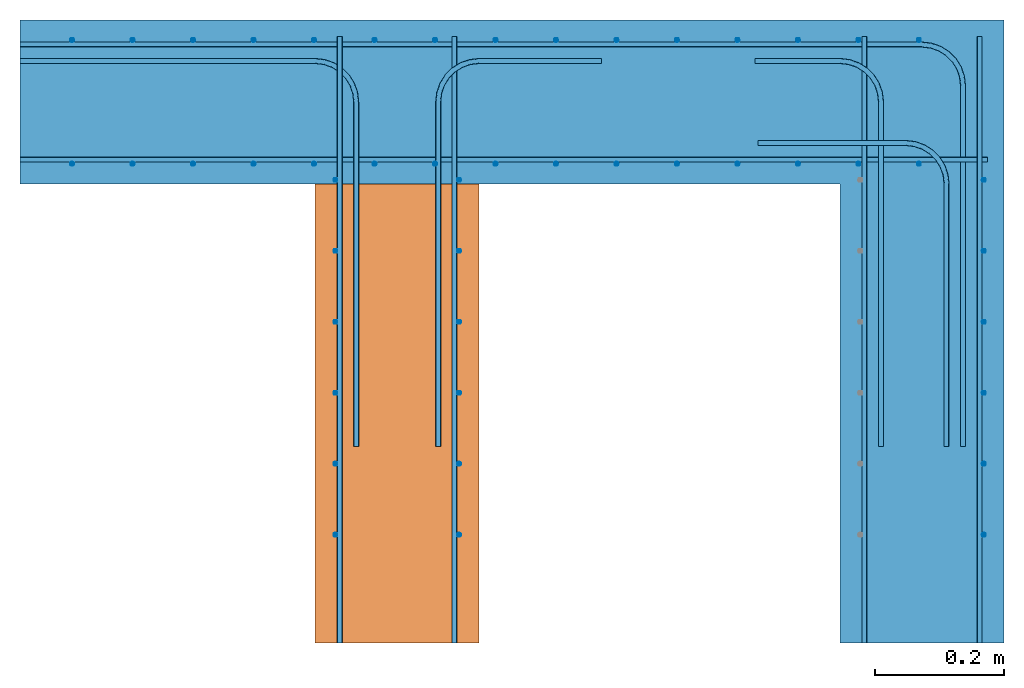
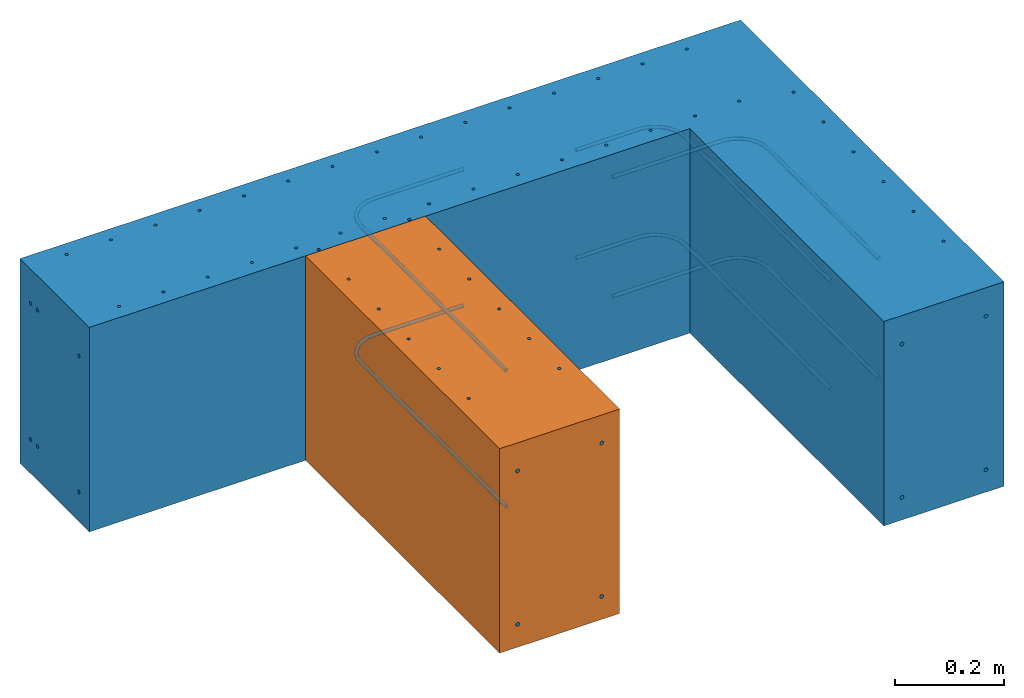
# One storey, part 1 of 2: 15 reinforcing bars, 1 proxy, 1 wall, 1 element without a shape of its own.
"""IFC4 building model written with IfcOpenShell, lengths in metres."""

from ifc_helpers import new_model, entity, si_unit, converted_unit, direction, frame, frame_2d, origin_with_axes, place, context, subcontext, project, spatial, polyline, rectangle, outline, extrude, element, aggregate, save


model = new_model("IFC4")

# Units and contexts
model_context = context("Model", 3, precision=1e-05, world=origin_with_axes(), true_north=direction((0.0, 1.0)))
body_context = subcontext(model_context, "Body", "Model", "MODEL_VIEW")
ifc_project = project(units=[si_unit("LENGTHUNIT", "METRE"), si_unit("AREAUNIT", "SQUARE_METRE"), si_unit("VOLUMEUNIT", "CUBIC_METRE"), converted_unit("PLANEANGLEUNIT", "DEGREE", entity("IfcPlaneAngleMeasure", 0.017453292519943295), si_unit("PLANEANGLEUNIT", "RADIAN"), dimensions=[0, 0, 0, 0, 0, 0, 0])], contexts=[model_context])

# Site, building, storey
site = spatial("IfcSite", under=ifc_project, CompositionType="ELEMENT")
building = spatial("IfcBuilding", under=site, Name="Default Building", CompositionType="ELEMENT")
storey = spatial("IfcBuildingStorey", under=building, Name="Detail 1", CompositionType="COMPLEX")

# Wall, proxy
placement = place(None, origin_with_axes())
wall = element("IfcWall", 1, at=placement, inside=storey, Name="Wall", PredefinedType="MOVABLE", context=body_context, shape_type="SweptSolid", body=[
    extrude(outline(polyline([(-0.964045454545477, 0.280554545454547), (0.559954545454545, 0.280554545454545), (0.559954545454545, -0.684645454545454), (0.305954545454514, -0.684645454545462), (0.305954545454492, 0.0265545454545304), (-0.964045454545499, 0.0265545454545399), (-0.964045454545477, 0.280554545454547)])), frame((0.964045454545455, -0.280554545454545, 0.0254), z_axis=(0.0, 0.0, 1.0), x_axis=(1.0, 0.0, 0.0)), (0.0, 0.0, -1.0), 0.4572),
])
proxy = element("IfcBuildingElementProxy", 2, at=placement, Name="Wall", PredefinedType="ELEMENT", context=body_context, shape_type="SweptSolid", body=[
    extrude(rectangle(XDim=0.7112, YDim=0.254, at=frame_2d((0.0, 0.0), x_axis=(0.0, 1.0))), frame((0.5842, -0.6096, 0.0254), z_axis=(0.0, 0.0, 1.0), x_axis=(1.0, 0.0, 0.0)), (0.0, 0.0, -1.0), 0.4572),
])
aggregate(wall, [proxy])

# Reinforcing bar
element("IfcReinforcingBar", 3, at=placement, inside=storey, Name="Stirrup", context=body_context, shape_type="SweptSolid", body=[
    entity("IfcSweptDiskSolid", entity("IfcCompositeCurve", [entity("IfcCompositeCurveSegment", "CONTINUOUS", True, entity("IfcPolyline", [entity("IfcCartesianPoint", [0.0808354293823238, -0.0310999994069913, -0.431799999999999]), entity("IfcCartesianPoint", [0.0808354293823238, -0.0310999994069913, 0.0254000000000015])]))], False), 0.003),
    entity("IfcSweptDiskSolid", entity("IfcCompositeCurve", [entity("IfcCompositeCurveSegment", "CONTINUOUS", True, entity("IfcPolyline", [entity("IfcCartesianPoint", [0.174521143668038, -0.0310999994069913, -0.431799999999999]), entity("IfcCartesianPoint", [0.174521143668038, -0.0310999994069913, 0.0254000000000015])]))], False), 0.003),
    entity("IfcSweptDiskSolid", entity("IfcCompositeCurve", [entity("IfcCompositeCurveSegment", "CONTINUOUS", True, entity("IfcPolyline", [entity("IfcCartesianPoint", [0.268206857953752, -0.0310999994069913, -0.431799999999999]), entity("IfcCartesianPoint", [0.268206857953752, -0.0310999994069913, 0.0254000000000015])]))], False), 0.003),
    entity("IfcSweptDiskSolid", entity("IfcCompositeCurve", [entity("IfcCompositeCurveSegment", "CONTINUOUS", True, entity("IfcPolyline", [entity("IfcCartesianPoint", [0.361892572239467, -0.0310999994069913, -0.431799999999999]), entity("IfcCartesianPoint", [0.361892572239467, -0.0310999994069913, 0.0254000000000015])]))], False), 0.003),
    entity("IfcSweptDiskSolid", entity("IfcCompositeCurve", [entity("IfcCompositeCurveSegment", "CONTINUOUS", True, entity("IfcPolyline", [entity("IfcCartesianPoint", [0.455578286525181, -0.0310999994069913, -0.431799999999999]), entity("IfcCartesianPoint", [0.455578286525181, -0.0310999994069913, 0.0254000000000015])]))], False), 0.003),
    entity("IfcSweptDiskSolid", entity("IfcCompositeCurve", [entity("IfcCompositeCurveSegment", "CONTINUOUS", True, entity("IfcPolyline", [entity("IfcCartesianPoint", [0.549264000810895, -0.0310999994069913, -0.431799999999999]), entity("IfcCartesianPoint", [0.549264000810895, -0.0310999994069913, 0.0254000000000015])]))], False), 0.003),
    entity("IfcSweptDiskSolid", entity("IfcCompositeCurve", [entity("IfcCompositeCurveSegment", "CONTINUOUS", True, entity("IfcPolyline", [entity("IfcCartesianPoint", [0.642949715096609, -0.0310999994069913, -0.431799999999999]), entity("IfcCartesianPoint", [0.642949715096609, -0.0310999994069913, 0.0254000000000015])]))], False), 0.003),
    entity("IfcSweptDiskSolid", entity("IfcCompositeCurve", [entity("IfcCompositeCurveSegment", "CONTINUOUS", True, entity("IfcPolyline", [entity("IfcCartesianPoint", [0.736635429382324, -0.0310999994069913, -0.431799999999999]), entity("IfcCartesianPoint", [0.736635429382324, -0.0310999994069913, 0.0254000000000015])]))], False), 0.003),
    entity("IfcSweptDiskSolid", entity("IfcCompositeCurve", [entity("IfcCompositeCurveSegment", "CONTINUOUS", True, entity("IfcPolyline", [entity("IfcCartesianPoint", [0.830321143668038, -0.0310999994069913, -0.431799999999999]), entity("IfcCartesianPoint", [0.830321143668038, -0.0310999994069913, 0.0254000000000015])]))], False), 0.003),
    entity("IfcSweptDiskSolid", entity("IfcCompositeCurve", [entity("IfcCompositeCurveSegment", "CONTINUOUS", True, entity("IfcPolyline", [entity("IfcCartesianPoint", [0.924006857953752, -0.0310999994069913, -0.431799999999999]), entity("IfcCartesianPoint", [0.924006857953752, -0.0310999994069913, 0.0254000000000015])]))], False), 0.003),
    entity("IfcSweptDiskSolid", entity("IfcCompositeCurve", [entity("IfcCompositeCurveSegment", "CONTINUOUS", True, entity("IfcPolyline", [entity("IfcCartesianPoint", [1.01769257223947, -0.0310999994069913, -0.431799999999999]), entity("IfcCartesianPoint", [1.01769257223947, -0.0310999994069913, 0.0254000000000015])]))], False), 0.003),
    entity("IfcSweptDiskSolid", entity("IfcCompositeCurve", [entity("IfcCompositeCurveSegment", "CONTINUOUS", True, entity("IfcPolyline", [entity("IfcCartesianPoint", [1.11137828652518, -0.0310999994069913, -0.431799999999999]), entity("IfcCartesianPoint", [1.11137828652518, -0.0310999994069913, 0.0254000000000015])]))], False), 0.003),
    entity("IfcSweptDiskSolid", entity("IfcCompositeCurve", [entity("IfcCompositeCurveSegment", "CONTINUOUS", True, entity("IfcPolyline", [entity("IfcCartesianPoint", [1.2050640008109, -0.0310999994069913, -0.431799999999999]), entity("IfcCartesianPoint", [1.2050640008109, -0.0310999994069913, 0.0254000000000015])]))], False), 0.003),
    entity("IfcSweptDiskSolid", entity("IfcCompositeCurve", [entity("IfcCompositeCurveSegment", "CONTINUOUS", True, entity("IfcPolyline", [entity("IfcCartesianPoint", [1.29874971509661, -0.0310999994069913, -0.431799999999999]), entity("IfcCartesianPoint", [1.29874971509661, -0.0310999994069913, 0.0254000000000015])]))], False), 0.003),
    entity("IfcSweptDiskSolid", entity("IfcCompositeCurve", [entity("IfcCompositeCurveSegment", "CONTINUOUS", True, entity("IfcPolyline", [entity("IfcCartesianPoint", [1.39243542938232, -0.0310999994069913, -0.431799999999999]), entity("IfcCartesianPoint", [1.39243542938232, -0.0310999994069913, 0.0254000000000015])]))], False), 0.003),
])

# Assembly, reinforcing bars
assembly = element("IfcElementAssembly", 4, inside=storey, Name="Compound")
reinforcing_bar_2 = element("IfcReinforcingBar", 5, at=placement, Name="Rebar", context=body_context, shape_type="SweptSolid", body=[
    entity("IfcSweptDiskSolid", entity("IfcCompositeCurve", [entity("IfcCompositeCurveSegment", "CONTINUOUS", True, entity("IfcPolyline", [entity("IfcCartesianPoint", [0.0, -0.0381000045696923, -0.0512667101383206]), entity("IfcCartesianPoint", [1.397, -0.0381000045696923, -0.0512667101383206])])), entity("IfcCompositeCurveSegment", "CONTINUOUS", True, entity("IfcTrimmedCurve", entity("IfcCircle", entity("IfcAxis2Placement3D", entity("IfcCartesianPoint", [1.397, -0.101600004569692, -0.0512667101383215]), entity("IfcDirection", [0.0, 0.0, -1.0]), entity("IfcDirection", [1.0, 0.0, 0.0])), 0.0635), [entity("IfcParameterValue", 270.0)], [entity("IfcParameterValue", 0.0)], True, "PARAMETER")), entity("IfcCompositeCurveSegment", "CONTINUOUS", True, entity("IfcPolyline", [entity("IfcCartesianPoint", [1.4605, -0.101600004569692, -0.0512667101383206]), entity("IfcCartesianPoint", [1.4605, -0.660400004569692, -0.0512667101383206])]))], False), 0.004),
    entity("IfcSweptDiskSolid", entity("IfcCompositeCurve", [entity("IfcCompositeCurveSegment", "CONTINUOUS", True, entity("IfcPolyline", [entity("IfcCartesianPoint", [0.0, -0.0381000045696923, -0.356066710138321]), entity("IfcCartesianPoint", [1.397, -0.0381000045696923, -0.356066710138321])])), entity("IfcCompositeCurveSegment", "CONTINUOUS", True, entity("IfcTrimmedCurve", entity("IfcCircle", entity("IfcAxis2Placement3D", entity("IfcCartesianPoint", [1.397, -0.101600004569692, -0.356066710138293]), entity("IfcDirection", [0.0, 0.0, -1.0]), entity("IfcDirection", [1.0, 0.0, 0.0])), 0.0635), [entity("IfcParameterValue", 270.0)], [entity("IfcParameterValue", 0.0)], True, "PARAMETER")), entity("IfcCompositeCurveSegment", "CONTINUOUS", True, entity("IfcPolyline", [entity("IfcCartesianPoint", [1.4605, -0.101600004569692, -0.356066710138321]), entity("IfcCartesianPoint", [1.4605, -0.660400004569692, -0.356066710138321])]))], False), 0.004),
])
reinforcing_bar_3 = element("IfcReinforcingBar", 6, at=placement, Name="Rebar", context=body_context, shape_type="SweptSolid", body=[
    entity("IfcSweptDiskSolid", entity("IfcCompositeCurve", [entity("IfcCompositeCurveSegment", "CONTINUOUS", True, entity("IfcPolyline", [entity("IfcCartesianPoint", [0.0, -0.0635000045696923, -0.0512667101383206]), entity("IfcCartesianPoint", [0.4572, -0.0635000045696923, -0.0512667101383206])])), entity("IfcCompositeCurveSegment", "CONTINUOUS", True, entity("IfcTrimmedCurve", entity("IfcCircle", entity("IfcAxis2Placement3D", entity("IfcCartesianPoint", [0.4572, -0.127000004569692, -0.0512667101383215]), entity("IfcDirection", [0.0, 0.0, -1.0]), entity("IfcDirection", [1.0, 0.0, 0.0])), 0.0635), [entity("IfcParameterValue", 270.0)], [entity("IfcParameterValue", 0.0)], True, "PARAMETER")), entity("IfcCompositeCurveSegment", "CONTINUOUS", True, entity("IfcPolyline", [entity("IfcCartesianPoint", [0.5207, -0.127000004569692, -0.0512667101383206]), entity("IfcCartesianPoint", [0.5207, -0.660400004569692, -0.0512667101383206])]))], False), 0.004),
    entity("IfcSweptDiskSolid", entity("IfcCompositeCurve", [entity("IfcCompositeCurveSegment", "CONTINUOUS", True, entity("IfcPolyline", [entity("IfcCartesianPoint", [0.0, -0.0635000045696923, -0.356066710138321]), entity("IfcCartesianPoint", [0.4572, -0.0635000045696923, -0.356066710138321])])), entity("IfcCompositeCurveSegment", "CONTINUOUS", True, entity("IfcTrimmedCurve", entity("IfcCircle", entity("IfcAxis2Placement3D", entity("IfcCartesianPoint", [0.4572, -0.127000004569692, -0.356066710138293]), entity("IfcDirection", [0.0, 0.0, -1.0]), entity("IfcDirection", [1.0, 0.0, 0.0])), 0.0635), [entity("IfcParameterValue", 270.0)], [entity("IfcParameterValue", 0.0)], True, "PARAMETER")), entity("IfcCompositeCurveSegment", "CONTINUOUS", True, entity("IfcPolyline", [entity("IfcCartesianPoint", [0.5207, -0.127000004569692, -0.356066710138321]), entity("IfcCartesianPoint", [0.5207, -0.660400004569692, -0.356066710138321])]))], False), 0.004),
])
reinforcing_bar_4 = element("IfcReinforcingBar", 7, at=placement, Name="Rebar", context=body_context, shape_type="SweptSolid", body=[
    entity("IfcSweptDiskSolid", entity("IfcCompositeCurve", [entity("IfcCompositeCurveSegment", "CONTINUOUS", True, entity("IfcPolyline", [entity("IfcCartesianPoint", [0.4953, -0.965200003748971, -0.0374972883224483]), entity("IfcCartesianPoint", [0.4953, -0.0254000037489707, -0.0374972883224483])]))], False), 0.004),
    entity("IfcSweptDiskSolid", entity("IfcCompositeCurve", [entity("IfcCompositeCurveSegment", "CONTINUOUS", True, entity("IfcPolyline", [entity("IfcCartesianPoint", [0.4953, -0.965200003748971, -0.380397288322448]), entity("IfcCartesianPoint", [0.4953, -0.0254000037489707, -0.380397288322448])]))], False), 0.004),
])
reinforcing_bar_5 = element("IfcReinforcingBar", 8, at=placement, Name="Rebar", context=body_context, shape_type="SweptSolid", body=[
    entity("IfcSweptDiskSolid", entity("IfcCompositeCurve", [entity("IfcCompositeCurveSegment", "CONTINUOUS", True, entity("IfcPolyline", [entity("IfcCartesianPoint", [0.6477, -0.660400004569692, -0.0512667101383206]), entity("IfcCartesianPoint", [0.6477, -0.127000004569692, -0.0512667101383206])])), entity("IfcCompositeCurveSegment", "CONTINUOUS", True, entity("IfcTrimmedCurve", entity("IfcCircle", entity("IfcAxis2Placement3D", entity("IfcCartesianPoint", [0.7112, -0.127000004569692, -0.0512667101383215]), entity("IfcDirection", [0.0, 0.0, -1.0]), entity("IfcDirection", [1.0, 0.0, 0.0])), 0.0635), [entity("IfcParameterValue", 180.0)], [entity("IfcParameterValue", 270.0)], True, "PARAMETER")), entity("IfcCompositeCurveSegment", "CONTINUOUS", True, entity("IfcPolyline", [entity("IfcCartesianPoint", [0.7112, -0.0635000045696923, -0.0512667101383206]), entity("IfcCartesianPoint", [0.900394409, -0.0635000045696923, -0.0512667101383206])]))], False), 0.004),
    entity("IfcSweptDiskSolid", entity("IfcCompositeCurve", [entity("IfcCompositeCurveSegment", "CONTINUOUS", True, entity("IfcPolyline", [entity("IfcCartesianPoint", [0.6477, -0.660400004569692, -0.356066710138321]), entity("IfcCartesianPoint", [0.6477, -0.127000004569692, -0.356066710138321])])), entity("IfcCompositeCurveSegment", "CONTINUOUS", True, entity("IfcTrimmedCurve", entity("IfcCircle", entity("IfcAxis2Placement3D", entity("IfcCartesianPoint", [0.7112, -0.127000004569692, -0.356066710138293]), entity("IfcDirection", [0.0, 0.0, -1.0]), entity("IfcDirection", [1.0, 0.0, 0.0])), 0.0635), [entity("IfcParameterValue", 180.0)], [entity("IfcParameterValue", 270.0)], True, "PARAMETER")), entity("IfcCompositeCurveSegment", "CONTINUOUS", True, entity("IfcPolyline", [entity("IfcCartesianPoint", [0.7112, -0.0635000045696923, -0.356066710138321]), entity("IfcCartesianPoint", [0.900394409, -0.0635000045696923, -0.356066710138321])]))], False), 0.004),
])
reinforcing_bar_6 = element("IfcReinforcingBar", 9, at=placement, Name="Rebar", context=body_context, shape_type="SweptSolid", body=[
    entity("IfcSweptDiskSolid", entity("IfcCompositeCurve", [entity("IfcCompositeCurveSegment", "CONTINUOUS", True, entity("IfcPolyline", [entity("IfcCartesianPoint", [0.0, -0.215900005162702, -0.0612157569885251]), entity("IfcCartesianPoint", [1.4986, -0.215900005162702, -0.0612157569885251])]))], False), 0.004),
    entity("IfcSweptDiskSolid", entity("IfcCompositeCurve", [entity("IfcCompositeCurveSegment", "CONTINUOUS", True, entity("IfcPolyline", [entity("IfcCartesianPoint", [0.0, -0.215900005162702, -0.366015756988525]), entity("IfcCartesianPoint", [1.4986, -0.215900005162702, -0.366015756988525])]))], False), 0.004),
])
reinforcing_bar_7 = element("IfcReinforcingBar", 10, at=placement, Name="Rebar", context=body_context, shape_type="SweptSolid", body=[
    entity("IfcSweptDiskSolid", entity("IfcCompositeCurve", [entity("IfcCompositeCurveSegment", "CONTINUOUS", True, entity("IfcPolyline", [entity("IfcCartesianPoint", [0.6731, -0.965200003748971, -0.0374972883224483]), entity("IfcCartesianPoint", [0.6731, -0.0254000037489707, -0.0374972883224483])]))], False), 0.004),
    entity("IfcSweptDiskSolid", entity("IfcCompositeCurve", [entity("IfcCompositeCurveSegment", "CONTINUOUS", True, entity("IfcPolyline", [entity("IfcCartesianPoint", [0.6731, -0.965200003748971, -0.380397288322448]), entity("IfcCartesianPoint", [0.6731, -0.0254000037489707, -0.380397288322448])]))], False), 0.004),
])
reinforcing_bar_8 = element("IfcReinforcingBar", 11, at=placement, Name="Rebar", context=body_context, shape_type="SweptSolid", body=[
    entity("IfcSweptDiskSolid", entity("IfcCompositeCurve", [entity("IfcCompositeCurveSegment", "CONTINUOUS", True, entity("IfcPolyline", [entity("IfcCartesianPoint", [1.3081, -0.965200003808575, -0.0384972883224485]), entity("IfcCartesianPoint", [1.3081, -0.0254000038085754, -0.0384972883224485])]))], False), 0.004),
    entity("IfcSweptDiskSolid", entity("IfcCompositeCurve", [entity("IfcCompositeCurveSegment", "CONTINUOUS", True, entity("IfcPolyline", [entity("IfcCartesianPoint", [1.3081, -0.965200003808575, -0.381397288322448]), entity("IfcCartesianPoint", [1.3081, -0.0254000038085754, -0.381397288322448])]))], False), 0.004),
])
reinforcing_bar_9 = element("IfcReinforcingBar", 12, at=placement, Name="Rebar", context=body_context, shape_type="SweptSolid", body=[
    entity("IfcSweptDiskSolid", entity("IfcCompositeCurve", [entity("IfcCompositeCurveSegment", "CONTINUOUS", True, entity("IfcPolyline", [entity("IfcCartesianPoint", [1.4859, -0.965200003808575, -0.0384972883224485]), entity("IfcCartesianPoint", [1.4859, -0.0254000038085754, -0.0384972883224485])]))], False), 0.004),
    entity("IfcSweptDiskSolid", entity("IfcCompositeCurve", [entity("IfcCompositeCurveSegment", "CONTINUOUS", True, entity("IfcPolyline", [entity("IfcCartesianPoint", [1.4859, -0.965200003808575, -0.381397288322449]), entity("IfcCartesianPoint", [1.4859, -0.0254000038085754, -0.381397288322449])]))], False), 0.004),
])
reinforcing_bar_10 = element("IfcReinforcingBar", 13, at=placement, Name="Rebar", context=body_context, shape_type="SweptSolid", body=[
    entity("IfcSweptDiskSolid", entity("IfcCompositeCurve", [entity("IfcCompositeCurveSegment", "CONTINUOUS", True, entity("IfcPolyline", [entity("IfcCartesianPoint", [1.138621338, -0.0635000070010764, -0.0920585642337798]), entity("IfcCartesianPoint", [1.27, -0.0635000070010764, -0.0920585642337798])])), entity("IfcCompositeCurveSegment", "CONTINUOUS", True, entity("IfcTrimmedCurve", entity("IfcCircle", entity("IfcAxis2Placement3D", entity("IfcCartesianPoint", [1.27, -0.127000007001076, -0.0920585642337812]), entity("IfcDirection", [0.0, 0.0, -1.0]), entity("IfcDirection", [1.0, 0.0, 0.0])), 0.0635), [entity("IfcParameterValue", 270.0)], [entity("IfcParameterValue", 0.0)], True, "PARAMETER")), entity("IfcCompositeCurveSegment", "CONTINUOUS", True, entity("IfcPolyline", [entity("IfcCartesianPoint", [1.3335, -0.127000007001076, -0.0920585642337798]), entity("IfcCartesianPoint", [1.3335, -0.660400007001076, -0.0920585642337798])]))], False), 0.004),
    entity("IfcSweptDiskSolid", entity("IfcCompositeCurve", [entity("IfcCompositeCurveSegment", "CONTINUOUS", True, entity("IfcPolyline", [entity("IfcCartesianPoint", [1.138621338, -0.0635000070010764, -0.33335856423378]), entity("IfcCartesianPoint", [1.27, -0.0635000070010764, -0.33335856423378])])), entity("IfcCompositeCurveSegment", "CONTINUOUS", True, entity("IfcTrimmedCurve", entity("IfcCircle", entity("IfcAxis2Placement3D", entity("IfcCartesianPoint", [1.27, -0.127000007001076, -0.333358564233777]), entity("IfcDirection", [0.0, 0.0, -1.0]), entity("IfcDirection", [1.0, 0.0, 0.0])), 0.0635), [entity("IfcParameterValue", 270.0)], [entity("IfcParameterValue", 0.0)], True, "PARAMETER")), entity("IfcCompositeCurveSegment", "CONTINUOUS", True, entity("IfcPolyline", [entity("IfcCartesianPoint", [1.3335, -0.127000007001076, -0.33335856423378]), entity("IfcCartesianPoint", [1.3335, -0.660400007001076, -0.33335856423378])]))], False), 0.004),
])
reinforcing_bar_11 = element("IfcReinforcingBar", 14, at=placement, Name="Rebar", context=body_context, shape_type="SweptSolid", body=[
    entity("IfcSweptDiskSolid", entity("IfcCompositeCurve", [entity("IfcCompositeCurveSegment", "CONTINUOUS", True, entity("IfcPolyline", [entity("IfcCartesianPoint", [1.142705322, -0.190500006088595, -0.0767496592044823]), entity("IfcCartesianPoint", [1.3716, -0.190500006088595, -0.0767496592044823])])), entity("IfcCompositeCurveSegment", "CONTINUOUS", True, entity("IfcTrimmedCurve", entity("IfcCircle", entity("IfcAxis2Placement3D", entity("IfcCartesianPoint", [1.3716, -0.254000006088595, -0.0767496592044807]), entity("IfcDirection", [0.0, 0.0, -1.0]), entity("IfcDirection", [1.0, 0.0, 0.0])), 0.0635), [entity("IfcParameterValue", 270.0)], [entity("IfcParameterValue", 0.0)], True, "PARAMETER")), entity("IfcCompositeCurveSegment", "CONTINUOUS", True, entity("IfcPolyline", [entity("IfcCartesianPoint", [1.4351, -0.254000006088595, -0.0767496592044823]), entity("IfcCartesianPoint", [1.4351, -0.660400006088594, -0.0767496592044823])]))], False), 0.004),
    entity("IfcSweptDiskSolid", entity("IfcCompositeCurve", [entity("IfcCompositeCurveSegment", "CONTINUOUS", True, entity("IfcPolyline", [entity("IfcCartesianPoint", [1.142705322, -0.190500006088595, -0.343449659204482]), entity("IfcCartesianPoint", [1.3716, -0.190500006088595, -0.343449659204482])])), entity("IfcCompositeCurveSegment", "CONTINUOUS", True, entity("IfcTrimmedCurve", entity("IfcCircle", entity("IfcAxis2Placement3D", entity("IfcCartesianPoint", [1.3716, -0.254000006088595, -0.343449659204509]), entity("IfcDirection", [0.0, 0.0, -1.0]), entity("IfcDirection", [1.0, 0.0, 0.0])), 0.0635), [entity("IfcParameterValue", 270.0)], [entity("IfcParameterValue", 0.0)], True, "PARAMETER")), entity("IfcCompositeCurveSegment", "CONTINUOUS", True, entity("IfcPolyline", [entity("IfcCartesianPoint", [1.4351, -0.254000006088595, -0.343449659204482]), entity("IfcCartesianPoint", [1.4351, -0.660400006088594, -0.343449659204482])]))], False), 0.004),
])
aggregate(assembly, [reinforcing_bar_2, reinforcing_bar_3, reinforcing_bar_4, reinforcing_bar_5, reinforcing_bar_6, reinforcing_bar_7, reinforcing_bar_8, reinforcing_bar_9, reinforcing_bar_10, reinforcing_bar_11])

# Reinforcing bars
element("IfcReinforcingBar", 15, at=placement, inside=storey, Name="Stirrup", context=body_context, shape_type="SweptSolid", body=[
    entity("IfcSweptDiskSolid", entity("IfcCompositeCurve", [entity("IfcCompositeCurveSegment", "CONTINUOUS", True, entity("IfcPolyline", [entity("IfcCartesianPoint", [1.4929, -0.247823328959943, -0.431799999999998]), entity("IfcCartesianPoint", [1.4929, -0.247823328959943, 0.0254000000000021])]))], False), 0.003),
    entity("IfcSweptDiskSolid", entity("IfcCompositeCurve", [entity("IfcCompositeCurveSegment", "CONTINUOUS", True, entity("IfcPolyline", [entity("IfcCartesianPoint", [1.4929, -0.357743328959943, -0.431799999999998]), entity("IfcCartesianPoint", [1.4929, -0.357743328959943, 0.0254000000000021])]))], False), 0.003),
    entity("IfcSweptDiskSolid", entity("IfcCompositeCurve", [entity("IfcCompositeCurveSegment", "CONTINUOUS", True, entity("IfcPolyline", [entity("IfcCartesianPoint", [1.4929, -0.467663328959943, -0.431799999999998]), entity("IfcCartesianPoint", [1.4929, -0.467663328959943, 0.0254000000000021])]))], False), 0.003),
    entity("IfcSweptDiskSolid", entity("IfcCompositeCurve", [entity("IfcCompositeCurveSegment", "CONTINUOUS", True, entity("IfcPolyline", [entity("IfcCartesianPoint", [1.4929, -0.577583328959943, -0.431799999999998]), entity("IfcCartesianPoint", [1.4929, -0.577583328959943, 0.0254000000000021])]))], False), 0.003),
    entity("IfcSweptDiskSolid", entity("IfcCompositeCurve", [entity("IfcCompositeCurveSegment", "CONTINUOUS", True, entity("IfcPolyline", [entity("IfcCartesianPoint", [1.4929, -0.687503328959943, -0.431799999999998]), entity("IfcCartesianPoint", [1.4929, -0.687503328959943, 0.0254000000000021])]))], False), 0.003),
    entity("IfcSweptDiskSolid", entity("IfcCompositeCurve", [entity("IfcCompositeCurveSegment", "CONTINUOUS", True, entity("IfcPolyline", [entity("IfcCartesianPoint", [1.4929, -0.797423328959944, -0.431799999999998]), entity("IfcCartesianPoint", [1.4929, -0.797423328959944, 0.0254000000000021])]))], False), 0.003),
])
element("IfcReinforcingBar", 16, at=placement, inside=storey, Name="Stirrup", context=body_context, shape_type="SweptSolid", body=[
    entity("IfcSweptDiskSolid", entity("IfcCompositeCurve", [entity("IfcCompositeCurveSegment", "CONTINUOUS", True, entity("IfcPolyline", [entity("IfcCartesianPoint", [0.488659271240234, -0.247823328959943, -0.431799999999998]), entity("IfcCartesianPoint", [0.488659271240234, -0.247823328959943, 0.0254000000000021])]))], False), 0.003),
    entity("IfcSweptDiskSolid", entity("IfcCompositeCurve", [entity("IfcCompositeCurveSegment", "CONTINUOUS", True, entity("IfcPolyline", [entity("IfcCartesianPoint", [0.488659271240234, -0.357743328959943, -0.431799999999998]), entity("IfcCartesianPoint", [0.488659271240234, -0.357743328959943, 0.0254000000000021])]))], False), 0.003),
    entity("IfcSweptDiskSolid", entity("IfcCompositeCurve", [entity("IfcCompositeCurveSegment", "CONTINUOUS", True, entity("IfcPolyline", [entity("IfcCartesianPoint", [0.488659271240234, -0.467663328959943, -0.431799999999998]), entity("IfcCartesianPoint", [0.488659271240234, -0.467663328959943, 0.0254000000000021])]))], False), 0.003),
    entity("IfcSweptDiskSolid", entity("IfcCompositeCurve", [entity("IfcCompositeCurveSegment", "CONTINUOUS", True, entity("IfcPolyline", [entity("IfcCartesianPoint", [0.488659271240234, -0.577583328959943, -0.431799999999998]), entity("IfcCartesianPoint", [0.488659271240234, -0.577583328959943, 0.0254000000000021])]))], False), 0.003),
    entity("IfcSweptDiskSolid", entity("IfcCompositeCurve", [entity("IfcCompositeCurveSegment", "CONTINUOUS", True, entity("IfcPolyline", [entity("IfcCartesianPoint", [0.488659271240234, -0.687503328959943, -0.431799999999998]), entity("IfcCartesianPoint", [0.488659271240234, -0.687503328959943, 0.0254000000000021])]))], False), 0.003),
    entity("IfcSweptDiskSolid", entity("IfcCompositeCurve", [entity("IfcCompositeCurveSegment", "CONTINUOUS", True, entity("IfcPolyline", [entity("IfcCartesianPoint", [0.488659271240234, -0.797423328959944, -0.431799999999998]), entity("IfcCartesianPoint", [0.488659271240234, -0.797423328959944, 0.0254000000000021])]))], False), 0.003),
])
element("IfcReinforcingBar", 17, at=placement, inside=storey, Name="Stirrup", context=body_context, shape_type="SweptSolid", body=[
    entity("IfcSweptDiskSolid", entity("IfcCompositeCurve", [entity("IfcCompositeCurveSegment", "CONTINUOUS", True, entity("IfcPolyline", [entity("IfcCartesianPoint", [0.6801, -0.247823328959943, -0.431799999999998]), entity("IfcCartesianPoint", [0.6801, -0.247823328959943, 0.0254000000000021])]))], False), 0.003),
    entity("IfcSweptDiskSolid", entity("IfcCompositeCurve", [entity("IfcCompositeCurveSegment", "CONTINUOUS", True, entity("IfcPolyline", [entity("IfcCartesianPoint", [0.6801, -0.357743328959943, -0.431799999999998]), entity("IfcCartesianPoint", [0.6801, -0.357743328959943, 0.0254000000000021])]))], False), 0.003),
    entity("IfcSweptDiskSolid", entity("IfcCompositeCurve", [entity("IfcCompositeCurveSegment", "CONTINUOUS", True, entity("IfcPolyline", [entity("IfcCartesianPoint", [0.6801, -0.467663328959943, -0.431799999999998]), entity("IfcCartesianPoint", [0.6801, -0.467663328959943, 0.0254000000000021])]))], False), 0.003),
    entity("IfcSweptDiskSolid", entity("IfcCompositeCurve", [entity("IfcCompositeCurveSegment", "CONTINUOUS", True, entity("IfcPolyline", [entity("IfcCartesianPoint", [0.6801, -0.577583328959943, -0.431799999999998]), entity("IfcCartesianPoint", [0.6801, -0.577583328959943, 0.0254000000000021])]))], False), 0.003),
    entity("IfcSweptDiskSolid", entity("IfcCompositeCurve", [entity("IfcCompositeCurveSegment", "CONTINUOUS", True, entity("IfcPolyline", [entity("IfcCartesianPoint", [0.6801, -0.687503328959943, -0.431799999999998]), entity("IfcCartesianPoint", [0.6801, -0.687503328959943, 0.0254000000000021])]))], False), 0.003),
    entity("IfcSweptDiskSolid", entity("IfcCompositeCurve", [entity("IfcCompositeCurveSegment", "CONTINUOUS", True, entity("IfcPolyline", [entity("IfcCartesianPoint", [0.6801, -0.797423328959944, -0.431799999999998]), entity("IfcCartesianPoint", [0.6801, -0.797423328959944, 0.0254000000000021])]))], False), 0.003),
])
element("IfcReinforcingBar", 18, at=placement, inside=storey, Name="Stirrup", context=body_context, shape_type="SweptSolid", body=[
    entity("IfcSweptDiskSolid", entity("IfcCompositeCurve", [entity("IfcCompositeCurveSegment", "CONTINUOUS", True, entity("IfcPolyline", [entity("IfcCartesianPoint", [0.0808354293823238, -0.222844711303711, -0.431799999999999]), entity("IfcCartesianPoint", [0.0808354293823238, -0.222844711303711, 0.0254000000000015])]))], False), 0.003),
    entity("IfcSweptDiskSolid", entity("IfcCompositeCurve", [entity("IfcCompositeCurveSegment", "CONTINUOUS", True, entity("IfcPolyline", [entity("IfcCartesianPoint", [0.174521143668038, -0.222844711303711, -0.431799999999999]), entity("IfcCartesianPoint", [0.174521143668038, -0.222844711303711, 0.0254000000000015])]))], False), 0.003),
    entity("IfcSweptDiskSolid", entity("IfcCompositeCurve", [entity("IfcCompositeCurveSegment", "CONTINUOUS", True, entity("IfcPolyline", [entity("IfcCartesianPoint", [0.268206857953752, -0.222844711303711, -0.431799999999999]), entity("IfcCartesianPoint", [0.268206857953752, -0.222844711303711, 0.0254000000000015])]))], False), 0.003),
    entity("IfcSweptDiskSolid", entity("IfcCompositeCurve", [entity("IfcCompositeCurveSegment", "CONTINUOUS", True, entity("IfcPolyline", [entity("IfcCartesianPoint", [0.361892572239467, -0.222844711303711, -0.431799999999999]), entity("IfcCartesianPoint", [0.361892572239467, -0.222844711303711, 0.0254000000000015])]))], False), 0.003),
    entity("IfcSweptDiskSolid", entity("IfcCompositeCurve", [entity("IfcCompositeCurveSegment", "CONTINUOUS", True, entity("IfcPolyline", [entity("IfcCartesianPoint", [0.455578286525181, -0.222844711303711, -0.431799999999999]), entity("IfcCartesianPoint", [0.455578286525181, -0.222844711303711, 0.0254000000000015])]))], False), 0.003),
    entity("IfcSweptDiskSolid", entity("IfcCompositeCurve", [entity("IfcCompositeCurveSegment", "CONTINUOUS", True, entity("IfcPolyline", [entity("IfcCartesianPoint", [0.549264000810895, -0.222844711303711, -0.431799999999999]), entity("IfcCartesianPoint", [0.549264000810895, -0.222844711303711, 0.0254000000000015])]))], False), 0.003),
    entity("IfcSweptDiskSolid", entity("IfcCompositeCurve", [entity("IfcCompositeCurveSegment", "CONTINUOUS", True, entity("IfcPolyline", [entity("IfcCartesianPoint", [0.642949715096609, -0.222844711303711, -0.431799999999999]), entity("IfcCartesianPoint", [0.642949715096609, -0.222844711303711, 0.0254000000000015])]))], False), 0.003),
    entity("IfcSweptDiskSolid", entity("IfcCompositeCurve", [entity("IfcCompositeCurveSegment", "CONTINUOUS", True, entity("IfcPolyline", [entity("IfcCartesianPoint", [0.736635429382324, -0.222844711303711, -0.431799999999999]), entity("IfcCartesianPoint", [0.736635429382324, -0.222844711303711, 0.0254000000000015])]))], False), 0.003),
    entity("IfcSweptDiskSolid", entity("IfcCompositeCurve", [entity("IfcCompositeCurveSegment", "CONTINUOUS", True, entity("IfcPolyline", [entity("IfcCartesianPoint", [0.830321143668038, -0.222844711303711, -0.431799999999999]), entity("IfcCartesianPoint", [0.830321143668038, -0.222844711303711, 0.0254000000000015])]))], False), 0.003),
    entity("IfcSweptDiskSolid", entity("IfcCompositeCurve", [entity("IfcCompositeCurveSegment", "CONTINUOUS", True, entity("IfcPolyline", [entity("IfcCartesianPoint", [0.924006857953752, -0.222844711303711, -0.431799999999999]), entity("IfcCartesianPoint", [0.924006857953752, -0.222844711303711, 0.0254000000000015])]))], False), 0.003),
    entity("IfcSweptDiskSolid", entity("IfcCompositeCurve", [entity("IfcCompositeCurveSegment", "CONTINUOUS", True, entity("IfcPolyline", [entity("IfcCartesianPoint", [1.01769257223947, -0.222844711303711, -0.431799999999999]), entity("IfcCartesianPoint", [1.01769257223947, -0.222844711303711, 0.0254000000000015])]))], False), 0.003),
    entity("IfcSweptDiskSolid", entity("IfcCompositeCurve", [entity("IfcCompositeCurveSegment", "CONTINUOUS", True, entity("IfcPolyline", [entity("IfcCartesianPoint", [1.11137828652518, -0.222844711303711, -0.431799999999999]), entity("IfcCartesianPoint", [1.11137828652518, -0.222844711303711, 0.0254000000000015])]))], False), 0.003),
    entity("IfcSweptDiskSolid", entity("IfcCompositeCurve", [entity("IfcCompositeCurveSegment", "CONTINUOUS", True, entity("IfcPolyline", [entity("IfcCartesianPoint", [1.2050640008109, -0.222844711303711, -0.431799999999999]), entity("IfcCartesianPoint", [1.2050640008109, -0.222844711303711, 0.0254000000000015])]))], False), 0.003),
    entity("IfcSweptDiskSolid", entity("IfcCompositeCurve", [entity("IfcCompositeCurveSegment", "CONTINUOUS", True, entity("IfcPolyline", [entity("IfcCartesianPoint", [1.29874971509661, -0.222844711303711, -0.431799999999999]), entity("IfcCartesianPoint", [1.29874971509661, -0.222844711303711, 0.0254000000000015])]))], False), 0.003),
    entity("IfcSweptDiskSolid", entity("IfcCompositeCurve", [entity("IfcCompositeCurveSegment", "CONTINUOUS", True, entity("IfcPolyline", [entity("IfcCartesianPoint", [1.39243542938232, -0.222844711303711, -0.431799999999999]), entity("IfcCartesianPoint", [1.39243542938232, -0.222844711303711, 0.0254000000000015])]))], False), 0.003),
])

save(model, "model.ifc")
